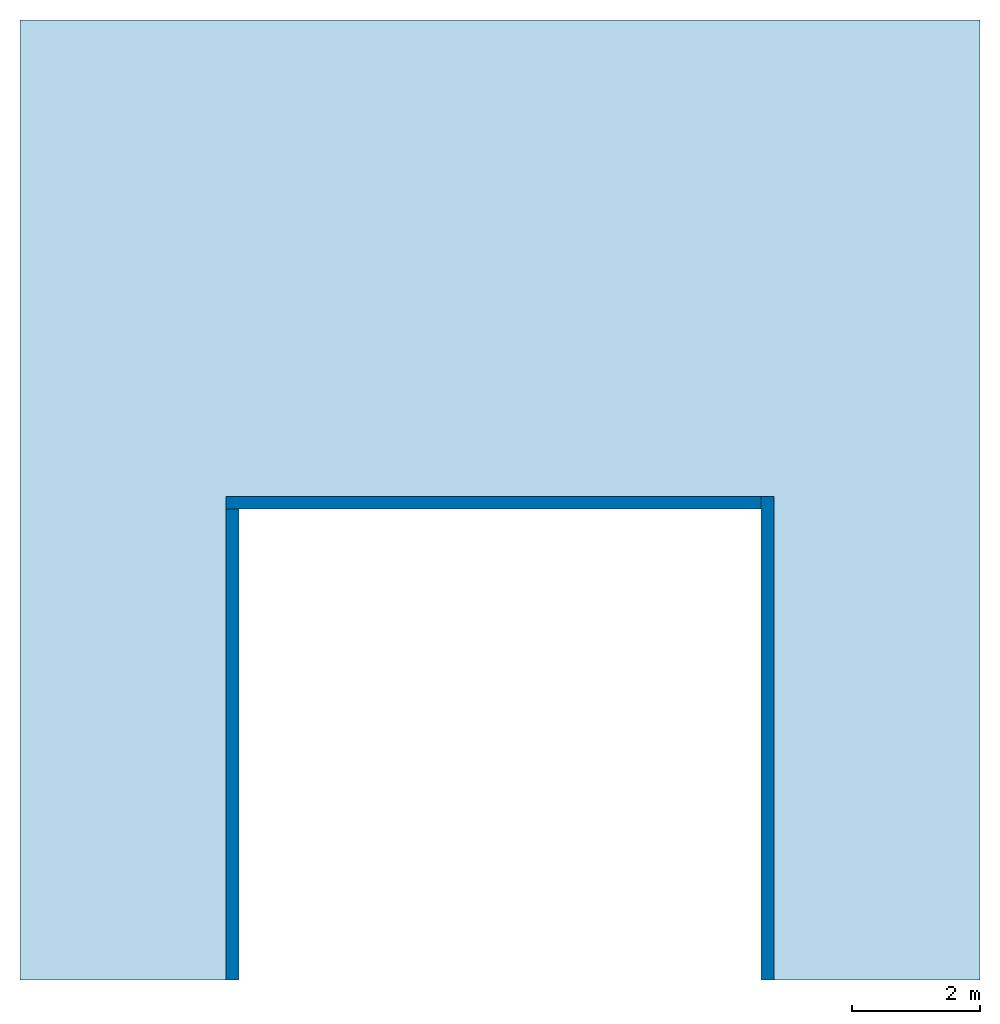
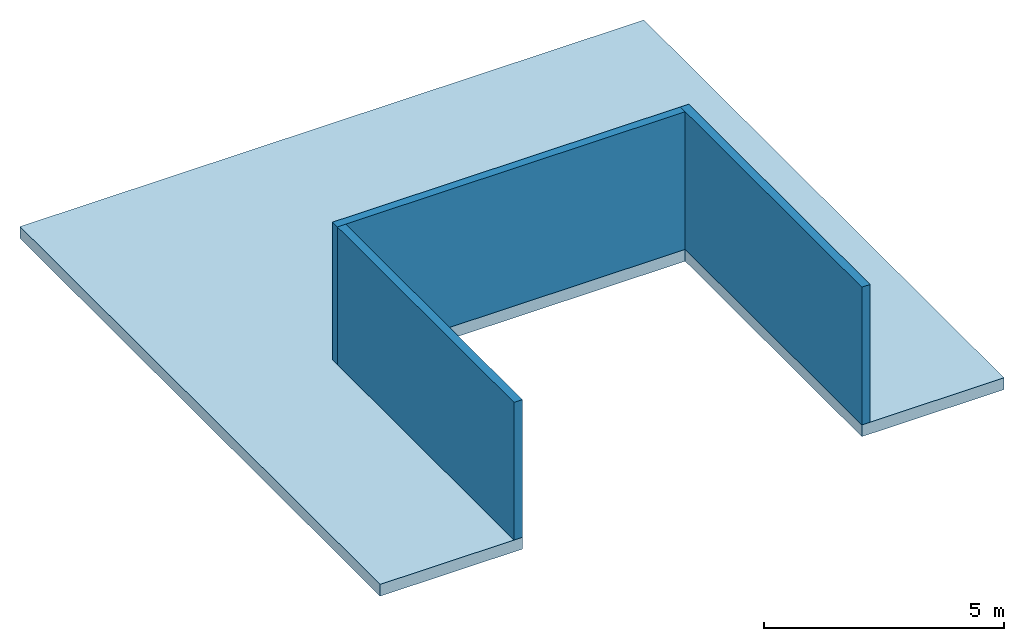
# One storey: 3 walls, 1 slab.
"""IFC2X3 building model written with IfcOpenShell, lengths in millimetres."""

from ifc_helpers import new_model, entity, si_unit, converted_unit, direction, frame, frame_2d, origin, place, context, subcontext, project, spatial, polyline, rectangle, outline, extrude, material, layer, layer_set, layer_usage, element, save


model = new_model("IFC2X3")

# Units and contexts
model_context = context("Model", 3, precision=1e-06, world=origin(), true_north=direction((2.0, 6.12303176911189e-17, 1.0)))
context_of_model = context(None, 3, precision=1e-06, world=origin(), true_north=direction((2.0, 6.12303176911189e-17, 1.0)))
body_context = subcontext(model_context, "Body", "Model", "MODEL_VIEW")
ifc_project = project(units=[si_unit("LENGTHUNIT", "METRE", prefix="MILLI"), si_unit("AREAUNIT", "SQUARE_METRE", prefix="MILLI"), si_unit("VOLUMEUNIT", "CUBIC_METRE", prefix="MILLI"), converted_unit("PLANEANGLEUNIT", "DEGREE", entity("IfcRatioMeasure", 0.0174532925199433), si_unit("PLANEANGLEUNIT", "RADIAN"), dimensions=[0, 0, 0, 0, 0, 0, 0]), si_unit("TIMEUNIT", "SECOND")], contexts=[model_context, context_of_model])

# Site, building, storey
site_placement = place(None, origin())
site = spatial("IfcSite", under=ifc_project, at=site_placement, CompositionType="ELEMENT")
building_placement = place(site_placement, origin())
building = spatial("IfcBuilding", under=site, at=building_placement, CompositionType="ELEMENT")
storey_placement = place(building_placement, frame((0.0, 0.0, 2800.0)))
storey = spatial("IfcBuildingStorey", under=building, at=storey_placement, Name="Level 2", CompositionType="ELEMENT", Elevation=2800.0)

# Slab
ifc_material_1 = material(Name="Default Floor")
ifc_layer_1 = layer(ifc_material_1, 300.0)
ifc_layer_set_1 = layer_set([ifc_layer_1], Name="Floor:Generic - 300mm")
ifc_layer_usage_1 = layer_usage(ifc_layer_set_1, "AXIS3", "POSITIVE", 0.0)
slab_placement = place(storey_placement, frame((-7866.43652722639, -7500.0, -300.0)))
element("IfcSlab", 1, at=slab_placement, inside=storey, material=ifc_layer_usage_1, Name="Floor:Generic - 300mm", ObjectType="Floor:Generic - 300mm", PredefinedType="FLOOR", context=body_context, shape_type="SweptSolid", body=[
    extrude(outline(polyline([(-7500.0, -7500.0), (-4081.5, -7500.0), (-4081.5, -143.0), (4081.5, -143.0), (4081.5, -7500.0), (7500.0, -7500.0), (7500.0, 7500.0), (-7500.0, 7500.0), (-7500.0, -7500.0)])), frame((7500.0, 7500.0, 300.0), z_axis=(0.0, 0.0, -1.0), x_axis=(-1.0, 0.0, 0.0)), (0.0, 0.0, 1.0), 300.0),
])

# Walls
ifc_material_2 = material(Name="Concrete")
ifc_layer_2 = layer(ifc_material_2, 200.0)
ifc_layer_set_2 = layer_set([ifc_layer_2], Name="Basic Wall:Interior - 200mm Concrete")
ifc_layer_usage_2 = layer_usage(ifc_layer_set_2, "AXIS2", "NEGATIVE", 100.0)
wall_1_placement = place(storey_placement, frame((3815.06347277361, -7500.0, 0.0), z_axis=(0.0, 0.0, 1.0), x_axis=(0.0, 1.0, 0.0)))
element("IfcWallStandardCase", 2, at=wall_1_placement, inside=storey, material=ifc_layer_usage_2, Name="Basic Wall:Interior - 200mm Concrete", ObjectType="Basic Wall:Interior - 200mm Concrete", context=body_context, shape_type="SweptSolid", body=[
    extrude(rectangle(XDim=7557.0, YDim=200.0, at=frame_2d((3778.5, -1.06581410364015e-13), x_axis=(-1.0, 0.0))), origin(), (0.0, 0.0, 1.0), 3500.0),
])
ifc_layer_usage_3 = layer_usage(ifc_layer_set_2, "AXIS2", "NEGATIVE", 100.0)
wall_2_placement = place(storey_placement, frame((3715.06347277362, -43.0, 0.0), z_axis=(0.0, 0.0, 1.0), x_axis=(-1.0, 0.0, 0.0)))
element("IfcWallStandardCase", 3, at=wall_2_placement, inside=storey, material=ifc_layer_usage_3, Name="Basic Wall:Interior - 200mm Concrete", ObjectType="Basic Wall:Interior - 200mm Concrete", context=body_context, shape_type="SweptSolid", body=[
    extrude(rectangle(XDim=8363.00000000001, YDim=200.0, at=frame_2d((4181.50000000001, 0.0), x_axis=(-1.0, 0.0))), origin(), (0.0, 0.0, 1.0), 3500.0),
])
ifc_layer_usage_4 = layer_usage(ifc_layer_set_2, "AXIS2", "NEGATIVE", 100.0)
wall_3_placement = place(storey_placement, frame((-4547.93652722639, -143.0, 0.0), z_axis=(0.0, 0.0, 1.0), x_axis=(0.0, -1.0, 0.0)))
element("IfcWallStandardCase", 4, at=wall_3_placement, inside=storey, material=ifc_layer_usage_4, Name="Basic Wall:Interior - 200mm Concrete", ObjectType="Basic Wall:Interior - 200mm Concrete", context=body_context, shape_type="SweptSolid", body=[
    extrude(rectangle(XDim=7357.00000000003, YDim=200.0, at=frame_2d((3678.50000000001, 0.0), x_axis=(-1.0, 0.0))), origin(), (0.0, 0.0, 1.0), 3500.0),
])

save(model, "model.ifc")
